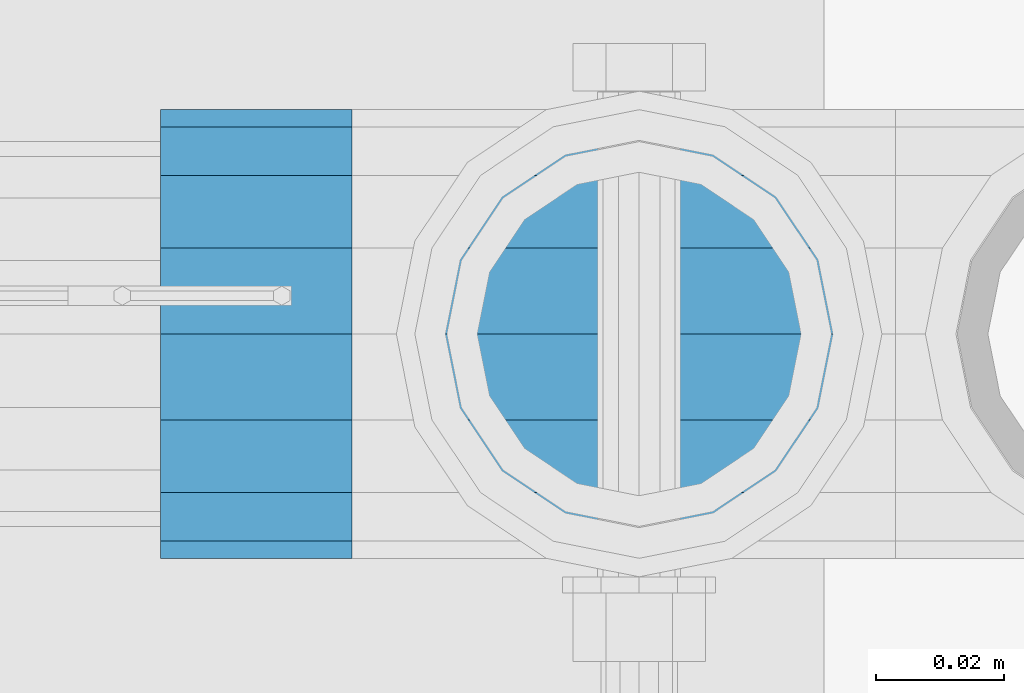
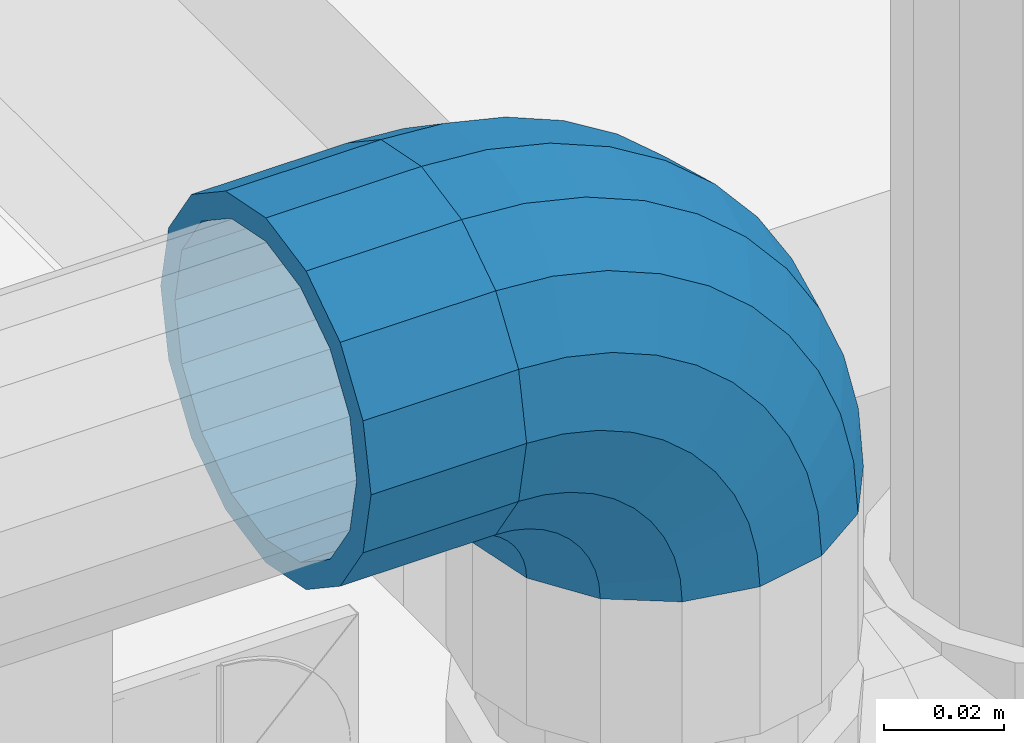
# One storey, part 164 of 240: 1 beam, 1 member.
"""IFC2X3 building model written with IfcOpenShell, lengths in millimetres."""

from ifc_helpers import new_model, si_unit, frame, origin_with_axes, place, context, subcontext, project, spatial, faceted_brep, material, type_object, element, save


model = new_model("IFC2X3")

# Units and contexts
model_context = context("Model", 3, precision=1e-05, world=origin_with_axes())
body_context = subcontext(model_context, "Body", "Model", "MODEL_VIEW")
ifc_project = project(units=[si_unit("LENGTHUNIT", "METRE", prefix="MILLI"), si_unit("AREAUNIT", "SQUARE_METRE"), si_unit("VOLUMEUNIT", "CUBIC_METRE"), si_unit("MASSUNIT", "GRAM", prefix="KILO"), si_unit("TIMEUNIT", "SECOND"), si_unit("PLANEANGLEUNIT", "RADIAN"), si_unit("SOLIDANGLEUNIT", "STERADIAN"), si_unit("THERMODYNAMICTEMPERATUREUNIT", "DEGREE_CELSIUS"), si_unit("LUMINOUSINTENSITYUNIT", "LUMEN")], contexts=[model_context])

# Site, building, storey
site_placement = place(None, origin_with_axes())
site = spatial("IfcSite", under=ifc_project, at=site_placement, CompositionType="ELEMENT")
building_placement = place(site_placement, origin_with_axes())
building = spatial("IfcBuilding", under=site, at=building_placement, Name="Standard", CompositionType="ELEMENT")
storey_placement = place(building_placement, origin_with_axes())
storey = spatial("IfcBuildingStorey", under=building, at=storey_placement, Name="Undefined", CompositionType="ELEMENT", Elevation=0.0)

# Beam
ifc_material = material(Name="Misc_Undefined")
beam_type = type_object("IfcBeamType", PredefinedType="NOTDEFINED")
beam_placement = place(storey_placement, frame((55836.0, 34664.5, 969.85), z_axis=(0.0, 0.0, 1.0), x_axis=(-1.0, 0.0, 0.0)))
element("IfcBeam", 1, at=beam_placement, inside=storey, type_object=beam_type, material=ifc_material, context=body_context, shape_type="Brep", body=[
    faceted_brep([(0.0, -30.3499999999985, 0.0), (0.0, -28.0397438117143, 11.6144421722784), (30.0, -28.0397438117143, 11.6144421722805), (30.0, -30.3499999999985, 0.0), (0.0, -21.4606908090136, 21.4606908090136), (30.0, -21.4606908090136, 21.4606908090117), (0.0, -11.6144421722784, 28.0397438117143), (30.0, -11.6144421722784, 28.0397438117176), (0.0, 0.0, 30.3499999999985), (30.0, 0.0, 30.35), (0.0, 11.6144421722784, 28.0397438117143), (30.0, 11.6144421722784, 28.0397438117176), (0.0, 21.4606908090136, 21.4606908090136), (30.0, 21.4606908090136, 21.4606908090117), (0.0, 28.0397438117143, 11.6144421722784), (30.0, 28.0397438117143, 11.6144421722805), (0.0, 30.3499999999985, 0.0), (30.0, 30.3499999999985, 0.0), (0.0, 28.0397438117143, -11.6144421722784), (30.0, 28.0397438117143, -11.6144421722805), (0.0, 21.4606908090136, -21.4606908090136), (30.0, 21.4606908090136, -21.4606908090117), (0.0, 11.6144421722784, -28.0397438117143), (30.0, 11.6144421722784, -28.0397438117176), (0.0, 0.0, -30.3499999999985), (30.0, 0.0, -30.35), (0.0, -11.6144421722784, -28.0397438117143), (30.0, -11.6144421722784, -28.0397438117176), (0.0, -21.4606908090136, -21.4606908090136), (30.0, -21.4606908090136, -21.4606908090117), (0.0, -28.0397438117143, -11.6144421722784), (30.0, -28.0397438117143, -11.6144421722805), (0.0, -35.1500000000015, 0.0), (0.0, -32.4743655677739, -13.4513226476338), (30.0, -32.4743655677739, -13.4513226476329), (30.0, -35.1500000000015, 0.0), (0.0, -24.8548033587067, -24.8548033587067), (30.0, -24.8548033587067, -24.8548033587072), (0.0, -13.4513226476338, -32.4743655677739), (30.0, -13.4513226476338, -32.4743655677718), (0.0, 0.0, -35.1500000000015), (30.0, 0.0, -35.15), (0.0, 13.4513226476338, -32.4743655677739), (30.0, 13.4513226476338, -32.4743655677718), (0.0, 24.8548033587067, -24.8548033587067), (30.0, 24.8548033587067, -24.8548033587072), (0.0, 32.4743655677739, -13.4513226476338), (30.0, 32.4743655677739, -13.4513226476329), (0.0, 35.1500000000015, 0.0), (30.0, 35.1500000000015, 0.0), (0.0, 32.4743655677739, 13.4513226476338), (30.0, 32.4743655677739, 13.4513226476329), (0.0, 24.8548033587067, 24.8548033587067), (30.0, 24.8548033587067, 24.8548033587072), (0.0, 13.4513226476338, 32.4743655677739), (30.0, 13.4513226476338, 32.4743655677718), (0.0, 0.0, 35.1500000000015), (30.0, 0.0, 35.15), (0.0, -13.4513226476338, 32.4743655677739), (30.0, -13.4513226476338, 32.4743655677718), (0.0, -24.8548033587067, 24.8548033587067), (30.0, -24.8548033587067, 24.8548033587072), (0.0, -32.4743655677739, 13.4513226476338), (30.0, -32.4743655677739, 13.4513226476329)], [[[0, 1, 2, 3]], [[1, 4, 5, 2]], [[4, 6, 7, 5]], [[6, 8, 9, 7]], [[8, 10, 11, 9]], [[10, 12, 13, 11]], [[12, 14, 15, 13]], [[14, 16, 17, 15]], [[16, 18, 19, 17]], [[18, 20, 21, 19]], [[20, 22, 23, 21]], [[22, 24, 25, 23]], [[24, 26, 27, 25]], [[26, 28, 29, 27]], [[28, 30, 31, 29]], [[30, 0, 3, 31]], [[32, 33, 34, 35]], [[33, 36, 37, 34]], [[36, 38, 39, 37]], [[38, 40, 41, 39]], [[40, 42, 43, 41]], [[42, 44, 45, 43]], [[44, 46, 47, 45]], [[46, 48, 49, 47]], [[48, 50, 51, 49]], [[50, 52, 53, 51]], [[52, 54, 55, 53]], [[54, 56, 57, 55]], [[56, 58, 59, 57]], [[58, 60, 61, 59]], [[60, 62, 63, 61]], [[62, 32, 35, 63]], [[37, 39, 41, 43, 45, 47, 49, 51, 53, 55, 57, 59, 61, 63, 35, 34], [5, 7, 9, 11, 13, 15, 17, 19, 21, 23, 25, 27, 29, 31, 3, 2]], [[62, 60, 58, 56, 54, 52, 50, 48, 46, 44, 42, 40, 38, 36, 33, 32], [30, 28, 26, 24, 22, 20, 18, 16, 14, 12, 10, 8, 6, 4, 1, 0]]]),
])

# Member
member_type = type_object("IfcMemberType", PredefinedType="NOTDEFINED")
member_placement = place(storey_placement, frame((55881.0, 34664.5, 924.85), z_axis=(0.707106781186541, -1.49999999888231e-07, 0.707106781186538), x_axis=(-0.707106781186548, 0.0, 0.707106781186548)))
element("IfcMember", 2, at=member_placement, inside=storey, type_object=member_type, material=ifc_material, context=body_context, shape_type="Brep", body=[
    faceted_brep([(0.0, -35.1500000000015, 0.0), (9.51152146006643, -32.4743655677739, -9.51152146006643), (13.2759578763362, -32.4743655677739, -6.29638902527222), (5.36946880023606, -35.1500000000015, 4.58595959348168), (17.5749999999971, -24.8548033587067, -17.5749999999971), (19.9787556631127, -24.8548033587067, -15.5219987155579), (22.9628441077002, -13.4513226476338, -22.9628441077002), (24.4574219585265, -13.4513226476338, -21.686354032383), (24.8548033587067, 0.0, -24.8548033587067), (26.0301204183124, 0.0, -23.8509877588003), (22.9628441077002, 13.4513226476338, -22.9628441077002), (24.4574219585265, 13.4513226476338, -21.686354032383), (17.5749999999971, 24.8548033587067, -17.5749999999971), (19.9787556631127, 24.8548033587067, -15.5219987155579), (9.51152146006643, 32.4743655677739, -9.51152146006643), (13.2759578763362, 32.4743655677739, -6.29638902527222), (0.0, 35.1500000000015, 0.0), (5.36946880023606, 35.1500000000015, 4.58595959348168), (-9.51152146007371, 32.4743655677739, 9.51152146007371), (-2.53702027587133, 32.4743655677739, 15.4683082122356), (-17.5749999999971, 24.8548033587067, 17.5750000000044), (-9.23981806264055, 24.8548033587067, 24.6939179025212), (-22.9628441077075, 13.4513226476338, 22.9628441077075), (-13.7184843580544, 13.4513226476338, 30.8582732193609), (-24.8548033587067, 0.0, 24.854803358714), (-15.2911828178476, 0.0, 33.0229069457637), (-22.9628441077075, -13.4513226476338, 22.9628441077075), (-13.7184843580544, -13.4513226476338, 30.8582732193609), (-17.5749999999971, -24.8548033587067, 17.5750000000044), (-9.23981806264055, -24.8548033587067, 24.6939179025212), (-9.51152146007371, -32.4743655677739, 9.51152146007371), (-2.53702027587133, -32.4743655677739, 15.4683082122356), (0.0, -30.3499999999985, 0.0), (-8.21265081971796, -28.0397438117143, 8.21265081971796), (-1.45732902223244, -28.0397438117143, 13.9822406910389), (5.36946880023606, -30.3499999999985, 4.58595959348168), (-15.1750000000029, -21.4606908090136, 15.1750000000029), (-7.24480876131565, -21.4606908090136, 21.9480231689959), (-19.8270929919963, -11.6144421722784, 19.8270929919963), (-11.1118790903492, -11.6144421722784, 27.2705888550845), (-21.4606908090136, 0.0, 21.4606908090136), (-12.46981360684, 0.0, 29.139625372758), (-19.8270929919963, 11.6144421722784, 19.8270929919963), (-11.1118790903492, 11.6144421722784, 27.2705888550845), (-15.1750000000029, 21.4606908090136, 15.1750000000029), (-7.24480876131565, 21.4606908090136, 21.9480231689959), (-8.21265081971796, 28.0397438117143, 8.21265081971796), (-1.45732902223244, 28.0397438117143, 13.9822406910389), (0.0, 30.3499999999985, 0.0), (5.36946880023606, 30.3499999999985, 4.58595959348168), (8.21265081971796, 28.0397438117143, -8.21265081971796), (12.1962666227046, 28.0397438117143, -4.81032150407555), (15.1750000000029, 21.4606908090136, -15.1749999999956), (17.9837463617805, 21.4606908090136, -12.7761039820398), (19.8270929919963, 11.6144421722784, -19.8270929919963), (21.8508166908287, 11.6144421722784, -18.0986696681139), (21.4606908090136, 0.0, -21.4606908090063), (23.2087512073122, 0.0, -19.9677061857947), (19.8270929919963, -11.6144421722784, -19.8270929919963), (21.8508166908287, -11.6144421722784, -18.0986696681139), (15.1750000000029, -21.4606908090136, -15.1749999999956), (17.9837463617805, -21.4606908090136, -12.7761039820398), (8.21265081971796, -28.0397438117143, -8.21265081971796), (12.1962666227046, -28.0397438117143, -4.81032150407555), (17.4970053560755, -32.4743655677739, -3.70972780291777), (11.390232665115, -35.1500000000015, 8.27548843508703), (22.6740772628618, -24.8548033587067, -13.8703035149447), (26.1332861179544, -13.4513226476338, -20.6593831546707), (27.347998730962, 0.0, -23.0433908901396), (26.1332861179544, 13.4513226476338, -20.6593831546707), (22.6740772628618, 24.8548033587067, -13.8703035149447), (17.4970053560755, 32.4743655677739, -3.70972780291777), (11.390232665115, 35.1500000000015, 8.27548843508703), (5.28345997416181, 32.4743655677739, 20.2607046730918), (0.106388067375519, 24.8548033587067, 30.4212803851042), (-3.35282078771706, 13.4513226476338, 37.210360024852), (-4.56753340072464, 0.0, 39.5943677603063), (-3.35282078771706, -13.4513226476338, 37.210360024852), (0.106388067375519, -24.8548033587067, 30.4212803851042), (5.28345997416181, -32.4743655677739, 20.2607046730918), (6.11738625913131, -28.0397438117143, 18.6240321853984), (11.390232665115, -30.3499999999985, 8.27548843508703), (1.64728291997744, -21.4606908090136, 27.3971039595053), (-1.33954464053386, -11.6144421722784, 33.2590831078996), (-2.38837900197541, 0.0, 35.3175364442068), (-1.33954464053386, 11.6144421722784, 33.2590831078996), (1.64728291997744, 21.4606908090136, 27.3971039595053), (6.11738625913131, 28.0397438117143, 18.6240321853984), (11.390232665115, 30.3499999999985, 8.27548843508703), (16.663079071106, 28.0397438117143, -2.07305531522434), (21.1331824102599, 21.4606908090136, -10.8461270893313), (24.1200099707639, 11.6144421722784, -16.7081062377256), (25.1688443322128, 0.0, -18.7665595740255), (24.1200099707639, -11.6144421722784, -16.7081062377256), (21.1331824102599, -21.4606908090136, -10.8461270893313), (16.663079071106, -28.0397438117143, -2.07305531522434), (22.070727701459, -32.4743655677739, -1.81522997692809), (17.9140404065256, -35.1500000000015, 10.9777380798914), (25.5945970362081, -24.8548033587067, -12.6605846156453), (27.9491712485105, -13.4513226476338, -19.9072189058861), (28.7759877588032, 0.0, -22.4518984678798), (27.9491712485105, 13.4513226476338, -19.9072189058861), (25.5945970362081, 24.8548033587067, -12.6605846156453), (22.070727701459, 32.4743655677739, -1.81522997692809), (17.9140404065256, 35.1500000000015, 10.9777380798914), (13.7573531115777, 32.4743655677739, 23.7707061367109), (10.2334837768358, 24.8548033587067, 34.6160607754209), (7.87890956454066, 13.4513226476338, 41.862695065669), (7.05209305424796, 0.0, 44.4073746276699), (7.87890956454066, -13.4513226476338, 41.862695065669), (10.2334837768358, -24.8548033587067, 34.6160607754209), (13.7573531115777, -32.4743655677739, 23.7707061367109), (14.3249803951039, -28.0397438117143, 22.023728990971), (17.9140404065256, -30.3499999999985, 10.9777380798914), (11.2823222355146, -21.4606908090136, 31.3880679180002), (9.24928305078356, -11.6144421722784, 37.6451191472734), (8.53537462724489, 0.0, 39.8423033494473), (9.24928305078356, 11.6144421722784, 37.6451191472734), (11.2823222355146, 21.4606908090136, 31.3880679180002), (14.3249803951039, 28.0397438117143, 22.023728990971), (17.9140404065256, 30.3499999999985, 10.9777380798914), (21.5031004179473, 28.0397438117143, -0.0682528311954229), (24.5457585775293, 21.4606908090136, -9.43259175821731), (26.5787977622676, 11.6144421722784, -15.6896429874905), (27.2927061858063, 0.0, -17.8868271896717), (26.5787977622676, -11.6144421722784, -15.6896429874905), (24.5457585775293, -21.4606908090136, -9.43259175821731), (21.5031004179473, -28.0397438117143, -0.0682528311954229), (26.8845046890492, -32.4743655677739, -0.659544371257653), (24.7802542265854, -35.1500000000015, 12.6261701733893), (28.6684020936882, -24.8548033587067, -11.9226293117827), (29.860364231703, -13.4513226476338, -19.4483820661189), (30.2789256727556, 0.0, -22.0910749985269), (29.860364231703, 13.4513226476338, -19.4483820661189), (28.6684020936882, 24.8548033587067, -11.9226293117827), (26.8845046890492, 32.4743655677739, -0.659544371257653), (24.7802542265854, 35.1500000000015, 12.6261701733893), (22.6760037641216, 32.4743655677739, 25.9118847180362), (20.8921063594826, 24.8548033587067, 37.1749696585684), (19.7001442214678, 13.4513226476338, 44.7007224129047), (19.2815827804225, 0.0, 47.3434153453127), (19.7001442214678, -13.4513226476338, 44.7007224129047), (20.8921063594826, -24.8548033587067, 37.1749696585684), (22.6760037641216, -32.4743655677739, 25.9118847180362), (22.9633551786319, -28.0397438117143, 24.0976192894668), (24.7802542265854, -30.3499999999985, 12.6261701733893), (21.4230625404889, -21.4606908090136, 33.8226442665691), (20.3938719035359, -11.6144421722784, 40.3206982095071), (20.0324682126156, 0.0, 42.6025113104479), (20.3938719035359, 11.6144421722784, 40.3206982095071), (21.4230625404889, 21.4606908090136, 33.8226442665691), (22.9633551786319, 28.0397438117143, 24.0976192894668), (24.7802542265854, 30.3499999999985, 12.6261701733893), (26.5971532745461, 28.0397438117143, 1.15472105731169), (28.1374459126891, 21.4606908090136, -8.57030391978333), (29.1666365496349, 11.6144421722784, -15.0683578627213), (29.5280402405551, 0.0, -17.3501709636694), (29.1666365496349, -11.6144421722784, -15.0683578627213), (28.1374459126891, -21.4606908090136, -8.57030391978333), (26.5971532745461, -28.0397438117143, 1.15472105731169), (31.8198051533982, -32.4743655677739, -0.271127801024704), (31.8198051533909, -35.1500000000015, 13.1801948466091), (31.8198051533982, -24.8548033587067, -11.6746085120976), (31.8198051533909, -13.4513226476338, -19.2941707211648), (31.8198051533982, 0.0, -21.9698051533924), (31.8198051533909, 13.4513226476338, -19.2941707211648), (31.8198051533982, 24.8548033587067, -11.6746085120976), (31.8198051533982, 32.4743655677739, -0.271127801024704), (31.8198051533909, 35.1500000000015, 13.1801948466091), (31.8198051533982, 32.4743655677739, 26.6315174942429), (31.8198051533982, 24.8548033587067, 38.0349982053158), (31.8198051533909, 13.4513226476338, 45.654560414383), (31.8198051533982, 0.0, 48.3301948466178), (31.8198051533909, -13.4513226476338, 45.654560414383), (31.8198051533982, -24.8548033587067, 38.0349982053158), (31.8198051533982, -32.4743655677739, 26.6315174942429), (31.8198051533982, -28.0397438117143, 24.7946370188947), (31.8198051533909, -30.3499999999985, 13.1801948466091), (31.8198051533982, -21.4606908090136, 34.6408856556227), (31.8198051533982, -11.6144421722784, 41.2199386583306), (31.8198051533982, 0.0, 43.5301948466076), (31.8198051533982, 11.6144421722784, 41.2199386583306), (31.8198051533982, 21.4606908090136, 34.6408856556227), (31.8198051533982, 28.0397438117143, 24.7946370188947), (31.8198051533909, 30.3499999999985, 13.1801948466091), (31.8198051533982, 28.0397438117143, 1.56575267433072), (31.8198051533982, 21.4606908090136, -8.28049596239725), (31.8198051533982, 11.6144421722784, -14.8595489651125), (31.8198051533982, 0.0, -17.1698051533895), (31.8198051533982, -11.6144421722784, -14.8595489651125), (31.8198051533982, -21.4606908090136, -8.28049596239725), (31.8198051533982, -28.0397438117143, 1.56575267433072), (36.7551056177399, -32.4743655677739, -0.659544371264928), (38.859356080211, -35.1500000000015, 12.6261701733965), (34.9712082131082, -24.8548033587067, -11.9226293117899), (33.7792460750934, -13.4513226476338, -19.4483820661189), (33.3606846340408, 0.0, -22.0910749985342), (33.7792460750934, 13.4513226476338, -19.4483820661189), (34.9712082131082, 24.8548033587067, -11.9226293117899), (36.7551056177399, 32.4743655677739, -0.659544371264928), (38.859356080211, 35.1500000000015, 12.6261701733965), (40.9636065426675, 32.4743655677739, 25.9118847180434), (42.7475039473065, 24.8548033587067, 37.1749696585684), (43.9394660853213, 13.4513226476338, 44.7007224129047), (44.3580275263739, 0.0, 47.3434153453054), (43.9394660853213, -13.4513226476338, 44.7007224129047), (42.7475039473065, -24.8548033587067, 37.1749696585684), (40.9636065426675, -32.4743655677739, 25.9118847180434), (40.6762551281645, -28.0397438117143, 24.0976192894668), (38.859356080211, -30.3499999999985, 12.6261701733965), (42.2165477663075, -21.4606908090136, 33.8226442665691), (43.2457384032605, -11.6144421722784, 40.3206982094998), (43.6071420941807, 0.0, 42.6025113104552), (43.2457384032605, 11.6144421722784, 40.3206982094998), (42.2165477663075, 21.4606908090136, 33.8226442665691), (40.6762551281645, 28.0397438117143, 24.0976192894668), (38.859356080211, 30.3499999999985, 12.6261701733965), (37.042457032243, 28.0397438117143, 1.15472105731169), (35.5021643941072, 21.4606908090136, -8.57030391978333), (34.4729737571543, 11.6144421722784, -15.068357862714), (34.111570066234, 0.0, -17.3501709636694), (34.4729737571543, -11.6144421722784, -15.068357862714), (35.5021643941072, -21.4606908090136, -8.57030391978333), (37.042457032243, -28.0397438117143, 1.15472105731169), (41.5688826053301, -32.4743655677739, -1.81522997692809), (45.7255699002708, -35.1500000000015, 10.9777380798987), (38.0450132705882, -24.8548033587067, -12.6605846156381), (35.6904390582786, -13.4513226476338, -19.9072189058934), (34.8636225479859, 0.0, -22.4518984678871), (35.6904390582786, 13.4513226476338, -19.9072189058934), (38.0450132705882, 24.8548033587067, -12.6605846156381), (41.5688826053301, 32.4743655677739, -1.81522997692809), (45.7255699002708, 35.1500000000015, 10.9777380798987), (49.8822571952041, 32.4743655677739, 23.7707061367109), (53.4061265299533, 24.8548033587067, 34.6160607754282), (55.7607007422557, 13.4513226476338, 41.862695065669), (56.5875172525484, 0.0, 44.4073746276626), (55.7607007422557, -13.4513226476338, 41.862695065669), (53.4061265299533, -24.8548033587067, 34.6160607754282), (49.8822571952041, -32.4743655677739, 23.7707061367109), (49.3146299116925, -28.0397438117143, 22.023728990971), (45.7255699002708, -30.3499999999985, 10.9777380798987), (52.3572880712745, -21.4606908090136, 31.3880679180002), (54.3903272560128, -11.6144421722784, 37.6451191472734), (55.1042356795515, 0.0, 39.8423033494473), (54.3903272560128, 11.6144421722784, 37.6451191472734), (52.3572880712745, 21.4606908090136, 31.3880679180002), (49.3146299116925, 28.0397438117143, 22.023728990971), (45.7255699002708, 30.3499999999985, 10.9777380798987), (42.1365098888491, 28.0397438117143, -0.068252831188147), (39.0938517292598, 21.4606908090136, -9.43259175821731), (37.0608125445287, 11.6144421722784, -15.6896429874905), (36.3469041209901, 0.0, -17.8868271896645), (37.0608125445287, -11.6144421722784, -15.6896429874905), (39.0938517292598, -21.4606908090136, -9.43259175821731), (42.1365098888491, -28.0397438117143, -0.068252831188147), (46.1426049507209, -32.4743655677739, -3.70972780291777), (52.2493776416741, -35.1500000000015, 8.27548843508703), (40.9655330439346, -24.8548033587067, -13.8703035149374), (37.506324188842, -13.4513226476338, -20.6593831546707), (36.2916115758271, 0.0, -23.0433908901323), (37.506324188842, 13.4513226476338, -20.6593831546707), (40.9655330439346, 24.8548033587067, -13.8703035149374), (46.1426049507209, 32.4743655677739, -3.70972780291777), (52.2493776416741, 35.1500000000015, 8.27548843508703), (58.3561503326346, 32.4743655677739, 20.2607046730918), (63.5332222394209, 24.8548033587067, 30.4212803851115), (66.9924310945134, 13.4513226476338, 37.2103600248447), (68.207143707521, 0.0, 39.5943677603063), (66.9924310945134, -13.4513226476338, 37.2103600248447), (63.5332222394209, -24.8548033587067, 30.4212803851115), (58.3561503326346, -32.4743655677739, 20.2607046730918), (57.5222240476651, -28.0397438117143, 18.6240321853984), (52.2493776416741, -30.3499999999985, 8.27548843508703), (61.9923273868189, -21.4606908090136, 27.3971039594981), (64.979154947323, -11.6144421722784, 33.2590831078924), (66.0279893087718, 0.0, 35.3175364442068), (64.979154947323, 11.6144421722784, 33.2590831078924), (61.9923273868189, 21.4606908090136, 27.3971039594981), (57.5222240476651, 28.0397438117143, 18.6240321853984), (52.2493776416741, 30.3499999999985, 8.27548843508703), (46.9765312356903, 28.0397438117143, -2.07305531523161), (42.5064278965365, 21.4606908090136, -10.8461270893313), (39.5196003360252, 11.6144421722784, -16.7081062377256), (38.4707659745836, 0.0, -18.7665595740327), (39.5196003360252, -11.6144421722784, -16.7081062377256), (42.5064278965365, -21.4606908090136, -10.8461270893313), (46.9765312356903, -28.0397438117143, -2.07305531523161), (50.3636524304529, -32.4743655677739, -6.2963890252795), (58.2701415065603, -35.1500000000015, 4.58595959348895), (43.6608546436837, -24.8548033587067, -15.5219987155579), (39.1821883482698, -13.4513226476338, -21.6863540323902), (37.6094898884767, 0.0, -23.8509877587931), (39.1821883482698, 13.4513226476338, -21.6863540323902), (43.6608546436837, 24.8548033587067, -15.5219987155579), (50.3636524304529, 32.4743655677739, -6.2963890252795), (58.2701415065603, 35.1500000000015, 4.58595959348895), (66.1766305826604, 32.4743655677739, 15.4683082122356), (72.8794283694297, 24.8548033587067, 24.6939179025212), (77.3580946648508, 13.4513226476338, 30.8582732193536), (78.9307931246367, 0.0, 33.0229069457637), (77.3580946648508, -13.4513226476338, 30.8582732193536), (72.8794283694297, -24.8548033587067, 24.6939179025212), (66.1766305826604, -32.4743655677739, 15.4683082122356), (65.0969393290288, -28.0397438117143, 13.9822406910462), (58.2701415065603, -30.3499999999985, 4.58595959348895), (70.884419068112, -21.4606908090136, 21.9480231689959), (74.7514893971456, -11.6144421722784, 27.2705888550845), (76.1094239136364, 0.0, 29.139625372758), (74.7514893971456, 11.6144421722784, 27.2705888550845), (70.884419068112, 21.4606908090136, 21.9480231689959), (65.0969393290288, 28.0397438117143, 13.9822406910462), (58.2701415065603, 30.3499999999985, 4.58595959348895), (51.4433436840845, 28.0397438117143, -4.81032150407555), (45.6558639450086, 21.4606908090136, -12.7761039820325), (41.7887936159677, 11.6144421722784, -18.0986696681211), (40.4308590994842, 0.0, -19.9677061858019), (41.7887936159677, -11.6144421722784, -18.0986696681211), (45.6558639450086, -21.4606908090136, -12.7761039820325), (51.4433436840845, -28.0397438117143, -4.81032150407555), (54.1280888467154, -32.4743655677739, -9.51152146006643), (63.6396103067891, -35.1500000000015, 7.27595761418343e-12), (46.0646103067847, -24.8548033587067, -17.5749999999971), (40.6767661990889, -13.4513226476338, -22.9628441077002), (38.7848069480824, 0.0, -24.8548033586994), (40.6767661990889, 13.4513226476338, -22.9628441077002), (46.0646103067847, 24.8548033587067, -17.5749999999971), (54.1280888467154, 32.4743655677739, -9.51152146006643), (63.6396103067891, 35.1500000000015, 7.27595761418343e-12), (73.1511317668555, 32.4743655677739, 9.51152146007371), (81.2146103067862, 24.8548033587067, 17.5750000000044), (86.6024544144893, 13.4513226476338, 22.9628441077075), (88.4944136654958, 0.0, 24.854803358714), (86.6024544144893, -13.4513226476338, 22.9628441077075), (81.2146103067862, -24.8548033587067, 17.5750000000044), (73.1511317668555, -32.4743655677739, 9.51152146007371), (71.8522611265071, -28.0397438117143, 8.21265081972524), (63.6396103067891, -30.3499999999985, 7.27595761418343e-12), (78.8146103067847, -21.4606908090136, 15.1750000000029), (83.4667032987854, -11.6144421722784, 19.8270929920036), (85.1003011158027, 0.0, 21.4606908090136), (83.4667032987854, 11.6144421722784, 19.8270929920036), (78.8146103067847, 21.4606908090136, 15.1750000000029), (71.8522611265071, 28.0397438117143, 8.21265081972524), (63.6396103067891, 30.3499999999985, 7.27595761418343e-12), (55.4269594870711, 28.0397438117143, -8.21265081971069), (48.4646103067862, 21.4606908090136, -15.1749999999956), (43.8125173147855, 11.6144421722784, -19.8270929919963), (42.1789194977755, 0.0, -21.4606908090063), (43.8125173147855, -11.6144421722784, -19.8270929919963), (48.4646103067862, -21.4606908090136, -15.1749999999956), (55.4269594870711, -28.0397438117143, -8.21265081971069)], [[[0, 1, 2, 3]], [[1, 4, 5, 2]], [[4, 6, 7, 5]], [[6, 8, 9, 7]], [[8, 10, 11, 9]], [[10, 12, 13, 11]], [[12, 14, 15, 13]], [[14, 16, 17, 15]], [[16, 18, 19, 17]], [[18, 20, 21, 19]], [[20, 22, 23, 21]], [[22, 24, 25, 23]], [[24, 26, 27, 25]], [[26, 28, 29, 27]], [[28, 30, 31, 29]], [[30, 0, 3, 31]], [[32, 33, 34, 35]], [[33, 36, 37, 34]], [[36, 38, 39, 37]], [[38, 40, 41, 39]], [[40, 42, 43, 41]], [[42, 44, 45, 43]], [[44, 46, 47, 45]], [[46, 48, 49, 47]], [[48, 50, 51, 49]], [[50, 52, 53, 51]], [[52, 54, 55, 53]], [[54, 56, 57, 55]], [[56, 58, 59, 57]], [[58, 60, 61, 59]], [[60, 62, 63, 61]], [[62, 32, 35, 63]], [[30, 28, 26, 24, 22, 20, 18, 16, 14, 12, 10, 8, 6, 4, 1, 0], [62, 60, 58, 56, 54, 52, 50, 48, 46, 44, 42, 40, 38, 36, 33, 32]], [[3, 2, 64, 65]], [[2, 5, 66, 64]], [[5, 7, 67, 66]], [[7, 9, 68, 67]], [[9, 11, 69, 68]], [[11, 13, 70, 69]], [[13, 15, 71, 70]], [[15, 17, 72, 71]], [[17, 19, 73, 72]], [[19, 21, 74, 73]], [[21, 23, 75, 74]], [[23, 25, 76, 75]], [[25, 27, 77, 76]], [[27, 29, 78, 77]], [[29, 31, 79, 78]], [[31, 3, 65, 79]], [[35, 34, 80, 81]], [[34, 37, 82, 80]], [[37, 39, 83, 82]], [[39, 41, 84, 83]], [[41, 43, 85, 84]], [[43, 45, 86, 85]], [[45, 47, 87, 86]], [[47, 49, 88, 87]], [[49, 51, 89, 88]], [[51, 53, 90, 89]], [[53, 55, 91, 90]], [[55, 57, 92, 91]], [[57, 59, 93, 92]], [[59, 61, 94, 93]], [[61, 63, 95, 94]], [[63, 35, 81, 95]], [[65, 64, 96, 97]], [[64, 66, 98, 96]], [[66, 67, 99, 98]], [[67, 68, 100, 99]], [[68, 69, 101, 100]], [[69, 70, 102, 101]], [[70, 71, 103, 102]], [[71, 72, 104, 103]], [[72, 73, 105, 104]], [[73, 74, 106, 105]], [[74, 75, 107, 106]], [[75, 76, 108, 107]], [[76, 77, 109, 108]], [[77, 78, 110, 109]], [[78, 79, 111, 110]], [[79, 65, 97, 111]], [[81, 80, 112, 113]], [[80, 82, 114, 112]], [[82, 83, 115, 114]], [[83, 84, 116, 115]], [[84, 85, 117, 116]], [[85, 86, 118, 117]], [[86, 87, 119, 118]], [[87, 88, 120, 119]], [[88, 89, 121, 120]], [[89, 90, 122, 121]], [[90, 91, 123, 122]], [[91, 92, 124, 123]], [[92, 93, 125, 124]], [[93, 94, 126, 125]], [[94, 95, 127, 126]], [[95, 81, 113, 127]], [[97, 96, 128, 129]], [[96, 98, 130, 128]], [[98, 99, 131, 130]], [[99, 100, 132, 131]], [[100, 101, 133, 132]], [[101, 102, 134, 133]], [[102, 103, 135, 134]], [[103, 104, 136, 135]], [[104, 105, 137, 136]], [[105, 106, 138, 137]], [[106, 107, 139, 138]], [[107, 108, 140, 139]], [[108, 109, 141, 140]], [[109, 110, 142, 141]], [[110, 111, 143, 142]], [[111, 97, 129, 143]], [[113, 112, 144, 145]], [[112, 114, 146, 144]], [[114, 115, 147, 146]], [[115, 116, 148, 147]], [[116, 117, 149, 148]], [[117, 118, 150, 149]], [[118, 119, 151, 150]], [[119, 120, 152, 151]], [[120, 121, 153, 152]], [[121, 122, 154, 153]], [[122, 123, 155, 154]], [[123, 124, 156, 155]], [[124, 125, 157, 156]], [[125, 126, 158, 157]], [[126, 127, 159, 158]], [[127, 113, 145, 159]], [[129, 128, 160, 161]], [[128, 130, 162, 160]], [[130, 131, 163, 162]], [[131, 132, 164, 163]], [[132, 133, 165, 164]], [[133, 134, 166, 165]], [[134, 135, 167, 166]], [[135, 136, 168, 167]], [[136, 137, 169, 168]], [[137, 138, 170, 169]], [[138, 139, 171, 170]], [[139, 140, 172, 171]], [[140, 141, 173, 172]], [[141, 142, 174, 173]], [[142, 143, 175, 174]], [[143, 129, 161, 175]], [[145, 144, 176, 177]], [[144, 146, 178, 176]], [[146, 147, 179, 178]], [[147, 148, 180, 179]], [[148, 149, 181, 180]], [[149, 150, 182, 181]], [[150, 151, 183, 182]], [[151, 152, 184, 183]], [[152, 153, 185, 184]], [[153, 154, 186, 185]], [[154, 155, 187, 186]], [[155, 156, 188, 187]], [[156, 157, 189, 188]], [[157, 158, 190, 189]], [[158, 159, 191, 190]], [[159, 145, 177, 191]], [[161, 160, 192, 193]], [[160, 162, 194, 192]], [[162, 163, 195, 194]], [[163, 164, 196, 195]], [[164, 165, 197, 196]], [[165, 166, 198, 197]], [[166, 167, 199, 198]], [[167, 168, 200, 199]], [[168, 169, 201, 200]], [[169, 170, 202, 201]], [[170, 171, 203, 202]], [[171, 172, 204, 203]], [[172, 173, 205, 204]], [[173, 174, 206, 205]], [[174, 175, 207, 206]], [[175, 161, 193, 207]], [[177, 176, 208, 209]], [[176, 178, 210, 208]], [[178, 179, 211, 210]], [[179, 180, 212, 211]], [[180, 181, 213, 212]], [[181, 182, 214, 213]], [[182, 183, 215, 214]], [[183, 184, 216, 215]], [[184, 185, 217, 216]], [[185, 186, 218, 217]], [[186, 187, 219, 218]], [[187, 188, 220, 219]], [[188, 189, 221, 220]], [[189, 190, 222, 221]], [[190, 191, 223, 222]], [[191, 177, 209, 223]], [[193, 192, 224, 225]], [[192, 194, 226, 224]], [[194, 195, 227, 226]], [[195, 196, 228, 227]], [[196, 197, 229, 228]], [[197, 198, 230, 229]], [[198, 199, 231, 230]], [[199, 200, 232, 231]], [[200, 201, 233, 232]], [[201, 202, 234, 233]], [[202, 203, 235, 234]], [[203, 204, 236, 235]], [[204, 205, 237, 236]], [[205, 206, 238, 237]], [[206, 207, 239, 238]], [[207, 193, 225, 239]], [[209, 208, 240, 241]], [[208, 210, 242, 240]], [[210, 211, 243, 242]], [[211, 212, 244, 243]], [[212, 213, 245, 244]], [[213, 214, 246, 245]], [[214, 215, 247, 246]], [[215, 216, 248, 247]], [[216, 217, 249, 248]], [[217, 218, 250, 249]], [[218, 219, 251, 250]], [[219, 220, 252, 251]], [[220, 221, 253, 252]], [[221, 222, 254, 253]], [[222, 223, 255, 254]], [[223, 209, 241, 255]], [[225, 224, 256, 257]], [[224, 226, 258, 256]], [[226, 227, 259, 258]], [[227, 228, 260, 259]], [[228, 229, 261, 260]], [[229, 230, 262, 261]], [[230, 231, 263, 262]], [[231, 232, 264, 263]], [[232, 233, 265, 264]], [[233, 234, 266, 265]], [[234, 235, 267, 266]], [[235, 236, 268, 267]], [[236, 237, 269, 268]], [[237, 238, 270, 269]], [[238, 239, 271, 270]], [[239, 225, 257, 271]], [[241, 240, 272, 273]], [[240, 242, 274, 272]], [[242, 243, 275, 274]], [[243, 244, 276, 275]], [[244, 245, 277, 276]], [[245, 246, 278, 277]], [[246, 247, 279, 278]], [[247, 248, 280, 279]], [[248, 249, 281, 280]], [[249, 250, 282, 281]], [[250, 251, 283, 282]], [[251, 252, 284, 283]], [[252, 253, 285, 284]], [[253, 254, 286, 285]], [[254, 255, 287, 286]], [[255, 241, 273, 287]], [[257, 256, 288, 289]], [[256, 258, 290, 288]], [[258, 259, 291, 290]], [[259, 260, 292, 291]], [[260, 261, 293, 292]], [[261, 262, 294, 293]], [[262, 263, 295, 294]], [[263, 264, 296, 295]], [[264, 265, 297, 296]], [[265, 266, 298, 297]], [[266, 267, 299, 298]], [[267, 268, 300, 299]], [[268, 269, 301, 300]], [[269, 270, 302, 301]], [[270, 271, 303, 302]], [[271, 257, 289, 303]], [[273, 272, 304, 305]], [[272, 274, 306, 304]], [[274, 275, 307, 306]], [[275, 276, 308, 307]], [[276, 277, 309, 308]], [[277, 278, 310, 309]], [[278, 279, 311, 310]], [[279, 280, 312, 311]], [[280, 281, 313, 312]], [[281, 282, 314, 313]], [[282, 283, 315, 314]], [[283, 284, 316, 315]], [[284, 285, 317, 316]], [[285, 286, 318, 317]], [[286, 287, 319, 318]], [[287, 273, 305, 319]], [[289, 288, 320, 321]], [[288, 290, 322, 320]], [[290, 291, 323, 322]], [[291, 292, 324, 323]], [[292, 293, 325, 324]], [[293, 294, 326, 325]], [[294, 295, 327, 326]], [[295, 296, 328, 327]], [[296, 297, 329, 328]], [[297, 298, 330, 329]], [[298, 299, 331, 330]], [[299, 300, 332, 331]], [[300, 301, 333, 332]], [[301, 302, 334, 333]], [[302, 303, 335, 334]], [[303, 289, 321, 335]], [[305, 304, 336, 337]], [[304, 306, 338, 336]], [[306, 307, 339, 338]], [[307, 308, 340, 339]], [[308, 309, 341, 340]], [[309, 310, 342, 341]], [[310, 311, 343, 342]], [[311, 312, 344, 343]], [[312, 313, 345, 344]], [[313, 314, 346, 345]], [[314, 315, 347, 346]], [[315, 316, 348, 347]], [[316, 317, 349, 348]], [[317, 318, 350, 349]], [[318, 319, 351, 350]], [[319, 305, 337, 351]], [[322, 323, 324, 325, 326, 327, 328, 329, 330, 331, 332, 333, 334, 335, 321, 320], [338, 339, 340, 341, 342, 343, 344, 345, 346, 347, 348, 349, 350, 351, 337, 336]]]),
])

save(model, "model.ifc")
